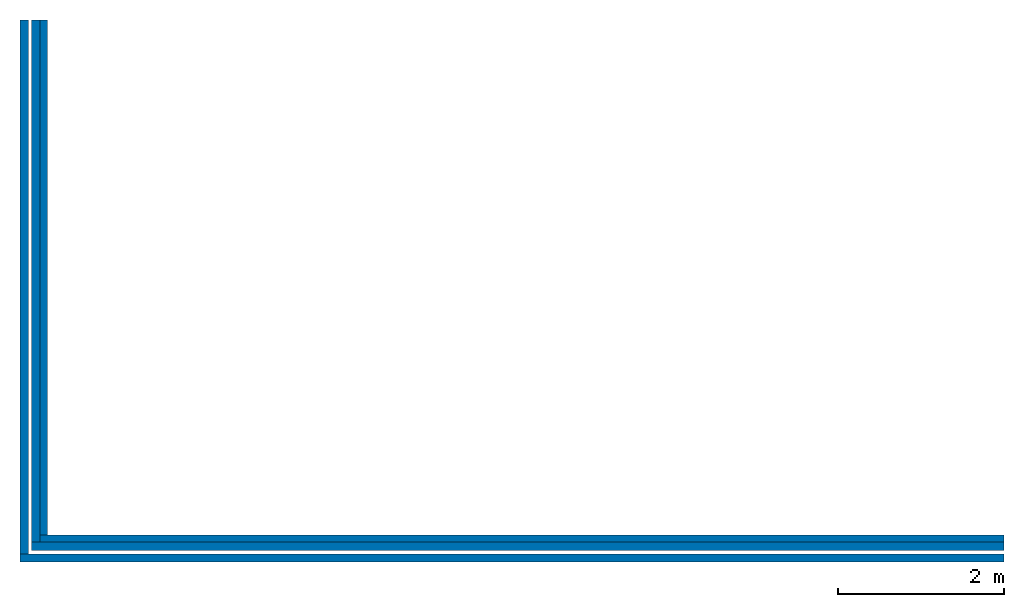
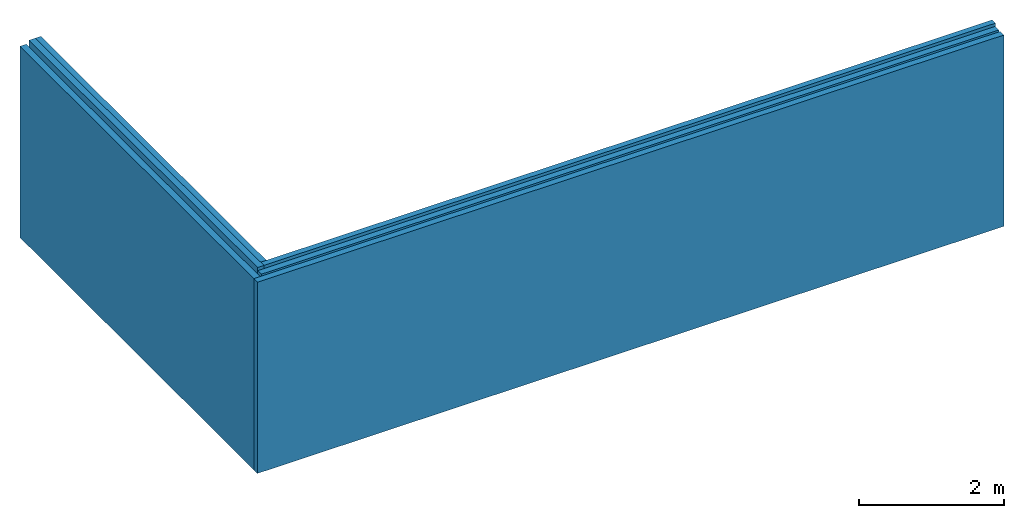
# One storey: 6 walls.
"""IFC4 building model written with IfcOpenShell, lengths in millimetres."""

from ifc_helpers import new_model, entity, si_unit, converted_unit, frame, origin_with_axes, origin_2d_with_axis, place, context, subcontext, project, spatial, indexed_curve, outline, extrude, material, layer, layer_set, layer_usage, type_object, element, save


model = new_model("IFC4")

# Units and contexts
model_context = context("Model", 3, precision=1e-05, world=origin_with_axes())
plan_context = context("Plan", 2, precision=1e-05, world=origin_2d_with_axis())
body_context = subcontext(model_context, "Body", "Model", "MODEL_VIEW")
ifc_project = project(units=[si_unit("VOLUMEUNIT", "CUBIC_METRE"), si_unit("LENGTHUNIT", "METRE", prefix="MILLI"), converted_unit("PLANEANGLEUNIT", "degree", entity("IfcReal", 0.0174532925199433), si_unit("PLANEANGLEUNIT", "RADIAN"), dimensions=[0, 0, 0, 0, 0, 0, 0]), si_unit("AREAUNIT", "SQUARE_METRE")], contexts=[model_context, plan_context])

# Site, building, storey
site_placement = place(None, origin_with_axes())
site = spatial("IfcSite", under=ifc_project, at=site_placement)
building_placement = place(site_placement, origin_with_axes())
building = spatial("IfcBuilding", under=site, at=building_placement, Name="Building")
storey_placement = place(building_placement, frame((0.0, 0.0, -52.0000457763672), z_axis=(0.0, 0.0, 1.0), x_axis=(1.0, 0.0, 0.0)))
storey = spatial("IfcBuildingStorey", under=building, at=storey_placement, Name="Begane Grond")

# Walls
ifc_material = material()
ifc_layer_1 = layer(ifc_material, 90.0)
ifc_layer_set_1 = layer_set([ifc_layer_1], Name="wood")
ifc_layer_usage_1 = layer_usage(ifc_layer_set_1, "AXIS2", "POSITIVE", 0.0)
wall_type_1 = type_object("IfcWallType", Name="CLT90", PredefinedType="ELEMENTEDWALL", material=ifc_layer_set_1)
wall_1_placement = place(storey_placement, frame((0.0, 0.0, 52.0000457763672), z_axis=(0.0, 0.0, 1.0), x_axis=(1.0, 0.0, 0.0)))
element("IfcWall", 1, at=wall_1_placement, inside=storey, type_object=wall_type_1, material=ifc_layer_usage_1, Name="Wall", context=body_context, shape_type="SweptSolid", body=[
    extrude(outline(indexed_curve([(0.0, 0.0), (0.0, 90.0), (11609.9999568916, 90.0), (11609.9999568916, 0.0), (0.0, 0.0)], self_intersect=False)), origin_with_axes(), (0.0, 0.0, 1.0), 3210.00003814697),
])
ifc_layer_usage_2 = layer_usage(ifc_layer_set_1, "AXIS2", "POSITIVE", 0.0)
wall_2_placement = place(storey_placement, frame((89.9999961256981, 90.0000035762787, 52.0000457763672), z_axis=(0.0, 0.0, 1.0), x_axis=(3.13916473260163e-07, 0.999999999999951, 0.0)))
element("IfcWall", 2, at=wall_2_placement, inside=storey, type_object=wall_type_1, material=ifc_layer_usage_2, Name="Wall", context=body_context, shape_type="SweptSolid", body=[
    extrude(outline(indexed_curve([(0.0, 0.0), (0.0, 90.0), (6199.99988925103, 90.0), (6199.99988925103, 0.0), (0.0, 0.0)], self_intersect=False)), origin_with_axes(), (0.0, 0.0, 1.0), 3210.00003814697),
])
ifc_layer_2 = layer(ifc_material, 100.0)
ifc_layer_set_2 = layer_set([ifc_layer_2], Name="iso")
ifc_layer_usage_3 = layer_usage(ifc_layer_set_2, "AXIS2", "POSITIVE", 0.0)
wall_type_2 = type_object("IfcWallType", Name="ISO100", PredefinedType="ELEMENTEDWALL", material=ifc_layer_set_2)
wall_3_placement = place(storey_placement, frame((-100.000001490116, -100.000001490116, 0.0), z_axis=(0.0, 0.0, 1.0), x_axis=(1.0, 0.0, 0.0)))
element("IfcWall", 3, at=wall_3_placement, inside=storey, type_object=wall_type_2, material=ifc_layer_usage_3, Name="Wall", context=body_context, shape_type="SweptSolid", body=[
    extrude(outline(indexed_curve([(0.0, 0.0), (0.0, 100.0), (11710.0012915893, 100.0), (11710.0012915893, 0.0), (0.0, 0.0)], self_intersect=False)), origin_with_axes(), (0.0, 0.0, 1.0), 3210.00003814697),
])
ifc_layer_usage_4 = layer_usage(ifc_layer_set_2, "AXIS2", "POSITIVE", 0.0)
wall_4_placement = place(storey_placement, frame((1.58549546824815e-05, 7.45058059692383e-06, 52.0000457763672), z_axis=(0.0, 0.0, 1.0), x_axis=(1.94707183709394e-07, 0.999999999999981, 0.0)))
element("IfcWall", 4, at=wall_4_placement, inside=storey, type_object=wall_type_2, material=ifc_layer_usage_4, Name="Wall", context=body_context, shape_type="SweptSolid", body=[
    extrude(outline(indexed_curve([(0.0, 0.0), (0.0, 100.0), (6289.99986948793, 100.0), (6289.99986948793, 0.0), (0.0, 0.0)], self_intersect=False)), origin_with_axes(), (0.0, 0.0, 1.0), 3210.00003814697),
])
ifc_layer_3 = layer(ifc_material, 100.0)
ifc_layer_set_3 = layer_set([ifc_layer_3], Name="brick")
ifc_layer_usage_5 = layer_usage(ifc_layer_set_3, "AXIS2", "POSITIVE", 0.0)
wall_type_3 = type_object("IfcWallType", Name="MW100", PredefinedType="ELEMENTEDWALL", material=ifc_layer_set_3)
wall_5_placement = place(storey_placement, frame((-141.395717859268, -139.999985694885, 0.0), z_axis=(0.0, 0.0, 1.0), x_axis=(7.54979012640431e-08, 0.999999999999997, 0.0)))
element("IfcWall", 5, at=wall_5_placement, inside=storey, type_object=wall_type_3, material=ifc_layer_usage_5, Name="Wall", context=body_context, shape_type="SweptSolid", body=[
    extrude(outline(indexed_curve([(0.0, 0.0), (0.0, 100.0), (6429.9998618881, 100.0), (6429.9998618881, 0.0), (0.0, 0.0)], self_intersect=False)), origin_with_axes(), (0.0, 0.0, 1.0), 3210.00003814697),
])
ifc_layer_usage_6 = layer_usage(ifc_layer_set_3, "AXIS2", "POSITIVE", 0.0)
wall_6_placement = place(storey_placement, frame((-241.395711898804, -240.000009536743, 1.38777878078145e-14), z_axis=(0.0, 0.0, 1.0), x_axis=(1.0, 0.0, 0.0)))
element("IfcWall", 6, at=wall_6_placement, inside=storey, type_object=wall_type_3, material=ifc_layer_usage_6, Name="Wall", context=body_context, shape_type="SweptSolid", body=[
    extrude(outline(indexed_curve([(0.0, 0.0), (0.0, 100.0), (11851.3957686443, 100.0), (11851.3957686443, 0.0), (0.0, 0.0)], self_intersect=False)), origin_with_axes(), (0.0, 0.0, 1.0), 3210.00003814697),
])

save(model, "model.ifc")
